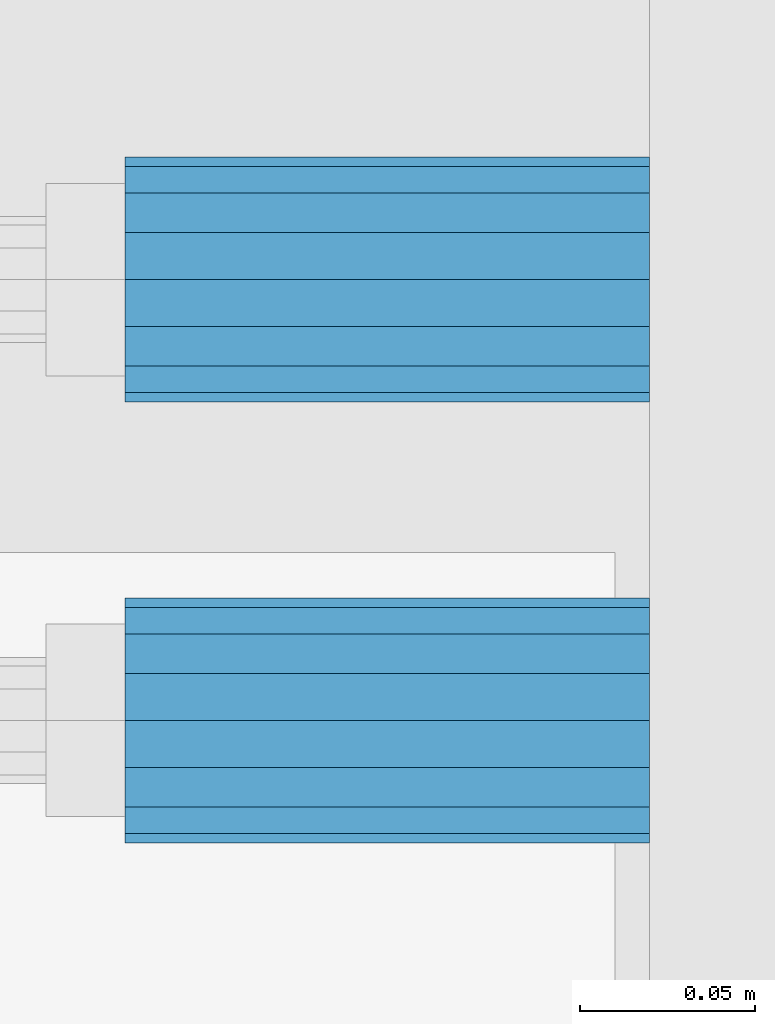
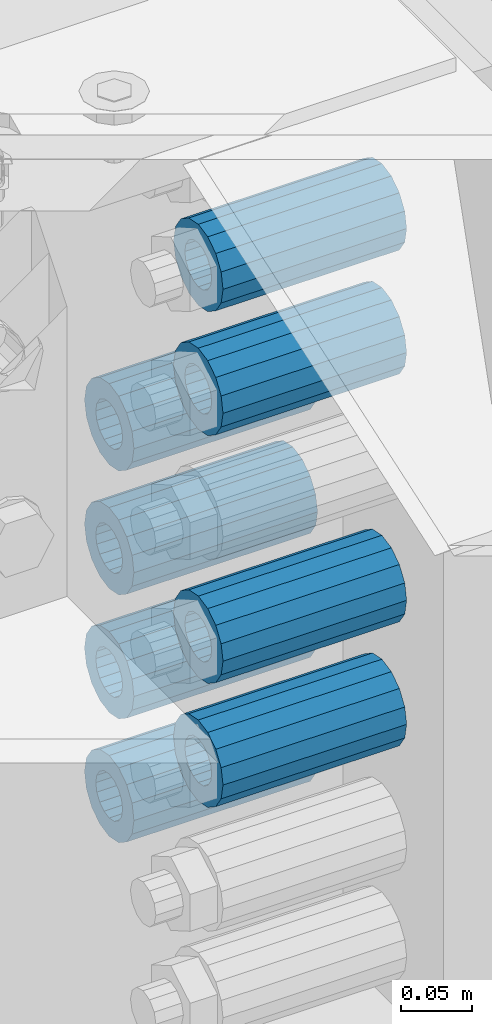
# One storey, part 143 of 208: 8 beams.
"""IFC2X3 building model written with IfcOpenShell, lengths in millimetres."""

from ifc_helpers import new_model, si_unit, frame, origin_with_axes, place, context, subcontext, project, spatial, faceted_brep, material, type_object, element, save


model = new_model("IFC2X3")

# Units and contexts
model_context = context("Model", 3, precision=1e-05, world=origin_with_axes())
body_context = subcontext(model_context, "Body", "Model", "MODEL_VIEW")
ifc_project = project(units=[si_unit("LENGTHUNIT", "METRE", prefix="MILLI"), si_unit("AREAUNIT", "SQUARE_METRE"), si_unit("VOLUMEUNIT", "CUBIC_METRE"), si_unit("MASSUNIT", "GRAM", prefix="KILO"), si_unit("TIMEUNIT", "SECOND"), si_unit("PLANEANGLEUNIT", "RADIAN"), si_unit("SOLIDANGLEUNIT", "STERADIAN"), si_unit("THERMODYNAMICTEMPERATUREUNIT", "DEGREE_CELSIUS"), si_unit("LUMINOUSINTENSITYUNIT", "LUMEN")], contexts=[model_context])

# Site, building, storey
site_placement = place(None, origin_with_axes())
site = spatial("IfcSite", under=ifc_project, at=site_placement, CompositionType="ELEMENT")
building_placement = place(site_placement, origin_with_axes())
building = spatial("IfcBuilding", under=site, at=building_placement, Name="Standard", CompositionType="ELEMENT")
storey_placement = place(building_placement, origin_with_axes())
storey = spatial("IfcBuildingStorey", under=building, at=storey_placement, Name="Undefined", CompositionType="ELEMENT", Elevation=0.0)

# Beams
ifc_material = material()
beam_type = type_object("IfcBeamType", PredefinedType="NOTDEFINED")
beam_1_placement = place(storey_placement, frame((-25783.0, 6063.0, -499.0), z_axis=(0.0, 0.0, 1.0), x_axis=(1.0, 0.0, 0.0)))
element("IfcBeam", 1, at=beam_1_placement, inside=storey, type_object=beam_type, material=ifc_material, context=body_context, shape_type="Brep", body=[
    faceted_brep([(-1.3120632047503e-07, -18.9999999995496, -6.26459950581193e-09), (0.0, -17.5537111177146, 7.27098521493672), (150.0, -17.5537111177146, 7.27098521493672), (150.0, -19.0, 0.0), (0.0, -13.4350288425444, 13.4350288425444), (150.0, -13.4350288425444, 13.4350288425444), (0.0, -7.2709852149369, 17.5537111177144), (150.0, -7.2709852149369, 17.5537111177144), (-6.33906438451959e-09, 4.50199877377599e-10, 18.9999999937354), (150.0, 0.0, 19.0), (0.0, 7.2709852149369, 17.5537111177144), (150.0, 7.2709852149369, 17.5537111177144), (0.0, 13.4350288425444, 13.4350288425444), (150.0, 13.4350288425444, 13.4350288425444), (0.0, 17.5537111177146, 7.2709852149367), (150.0, 17.5537111177146, 7.2709852149367), (1.33208345687308e-07, 19.0000000004507, -6.26459950581193e-09), (150.0, 19.0, 0.0), (0.0, 17.5537111177146, -7.2709852149367), (150.0, 17.5537111177146, -7.2709852149367), (0.0, 13.4350288425444, -13.4350288425444), (150.0, 13.4350288425444, -13.4350288425444), (0.0, 7.2709852149369, -17.5537111177144), (150.0, 7.2709852149369, -17.5537111177144), (8.34120328363497e-09, 4.50427251053043e-10, -19.0000000062646), (150.0, 0.0, -19.0), (0.0, -7.2709852149369, -17.5537111177144), (150.0, -7.2709852149369, -17.5537111177144), (0.0, -13.4350288425444, -13.4350288425444), (150.0, -13.4350288425444, -13.4350288425444), (0.0, -17.5537111177146, -7.2709852149367), (150.0, -17.5537111177146, -7.2709852149367), (0.0, -35.0, 0.0), (-3.63797880709171e-12, -32.335783637895, -13.3939201327782), (150.0, -32.335783637895, -13.3939201327782), (150.0, -35.0, 0.0), (0.0, -24.7487373415292, -24.7487373415291), (150.0, -24.7487373415293, -24.7487373415292), (0.0, -13.3939201327781, -32.335783637895), (150.0, -13.393920132778, -32.335783637895), (0.0, 0.0, -35.0), (150.0, 0.0, -35.0), (0.0, 13.3939201327782, -32.335783637895), (150.0, 13.393920132778, -32.335783637895), (0.0, 24.7487373415292, -24.7487373415291), (150.0, 24.7487373415293, -24.7487373415292), (-3.63797880709171e-12, 32.335783637895, -13.3939201327782), (150.0, 32.335783637895, -13.3939201327781), (0.0, 35.0, 0.0), (150.0, 35.0, 0.0), (0.0, 32.335783637895, 13.3939201327781), (150.0, 32.335783637895, 13.3939201327781), (0.0, 24.7487373415292, 24.748737341529), (150.0, 24.7487373415293, 24.7487373415292), (0.0, 13.3939201327781, 32.335783637895), (150.0, 13.393920132778, 32.335783637895), (-3.63797880709171e-12, 0.0, 35.0), (150.0, 0.0, 35.0), (0.0, -13.3939201327781, 32.335783637895), (150.0, -13.393920132778, 32.335783637895), (0.0, -24.7487373415292, 24.748737341529), (150.0, -24.7487373415293, 24.7487373415292), (0.0, -32.335783637895, 13.3939201327781), (150.0, -32.335783637895, 13.3939201327781)], [[[0, 1, 2, 3]], [[1, 4, 5, 2]], [[4, 6, 7, 5]], [[6, 8, 9, 7]], [[8, 10, 11, 9]], [[10, 12, 13, 11]], [[12, 14, 15, 13]], [[14, 16, 17, 15]], [[16, 18, 19, 17]], [[18, 20, 21, 19]], [[20, 22, 23, 21]], [[22, 24, 25, 23]], [[24, 26, 27, 25]], [[26, 28, 29, 27]], [[28, 30, 31, 29]], [[30, 0, 3, 31]], [[32, 33, 34, 35]], [[33, 36, 37, 34]], [[36, 38, 39, 37]], [[38, 40, 41, 39]], [[40, 42, 43, 41]], [[42, 44, 45, 43]], [[44, 46, 47, 45]], [[46, 48, 49, 47]], [[48, 50, 51, 49]], [[50, 52, 53, 51]], [[52, 54, 55, 53]], [[54, 56, 57, 55]], [[56, 58, 59, 57]], [[58, 60, 61, 59]], [[60, 62, 63, 61]], [[62, 32, 35, 63]], [[37, 39, 41, 43, 45, 47, 49, 51, 53, 55, 57, 59, 61, 63, 35, 34], [5, 7, 9, 11, 13, 15, 17, 19, 21, 23, 25, 27, 29, 31, 3, 2]], [[62, 60, 58, 56, 54, 52, 50, 48, 46, 44, 42, 40, 38, 36, 33, 32], [30, 28, 26, 24, 22, 20, 18, 16, 14, 12, 10, 8, 6, 4, 1, 0]]]),
])
beam_2_placement = place(storey_placement, frame((-25783.0, 5937.0, -285.0), z_axis=(0.0, 0.0, 1.0), x_axis=(1.0, 0.0, 0.0)))
element("IfcBeam", 2, at=beam_2_placement, inside=storey, type_object=beam_type, material=ifc_material, context=body_context, shape_type="Brep", body=[
    faceted_brep([(-1.3120632047503e-07, -18.9999999995496, -6.26459950581193e-09), (0.0, -17.5537111177146, 7.27098521493672), (150.0, -17.5537111177146, 7.27098521493672), (150.0, -19.0, 0.0), (0.0, -13.4350288425444, 13.4350288425444), (150.0, -13.4350288425444, 13.4350288425444), (0.0, -7.2709852149369, 17.5537111177144), (150.0, -7.2709852149369, 17.5537111177144), (-6.33906438451959e-09, 4.50199877377599e-10, 18.9999999937354), (150.0, 0.0, 19.0), (0.0, 7.2709852149369, 17.5537111177144), (150.0, 7.2709852149369, 17.5537111177144), (0.0, 13.4350288425444, 13.4350288425444), (150.0, 13.4350288425444, 13.4350288425444), (0.0, 17.5537111177146, 7.2709852149367), (150.0, 17.5537111177146, 7.2709852149367), (1.33208345687308e-07, 19.0000000004507, -6.26459950581193e-09), (150.0, 19.0, 0.0), (0.0, 17.5537111177146, -7.2709852149367), (150.0, 17.5537111177146, -7.2709852149367), (0.0, 13.4350288425444, -13.4350288425444), (150.0, 13.4350288425444, -13.4350288425444), (0.0, 7.2709852149369, -17.5537111177144), (150.0, 7.2709852149369, -17.5537111177144), (8.34120328363497e-09, 4.50427251053043e-10, -19.0000000062646), (150.0, 0.0, -19.0), (0.0, -7.2709852149369, -17.5537111177144), (150.0, -7.2709852149369, -17.5537111177144), (0.0, -13.4350288425444, -13.4350288425444), (150.0, -13.4350288425444, -13.4350288425444), (0.0, -17.5537111177146, -7.2709852149367), (150.0, -17.5537111177146, -7.2709852149367), (0.0, -35.0, 0.0), (-3.63797880709171e-12, -32.335783637895, -13.3939201327782), (150.0, -32.335783637895, -13.3939201327782), (150.0, -35.0, 0.0), (0.0, -24.7487373415292, -24.7487373415291), (150.0, -24.7487373415293, -24.7487373415292), (0.0, -13.3939201327781, -32.335783637895), (150.0, -13.393920132778, -32.335783637895), (0.0, 0.0, -35.0), (150.0, 0.0, -35.0), (0.0, 13.3939201327782, -32.335783637895), (150.0, 13.393920132778, -32.335783637895), (0.0, 24.7487373415292, -24.7487373415291), (150.0, 24.7487373415293, -24.7487373415292), (-3.63797880709171e-12, 32.335783637895, -13.3939201327782), (150.0, 32.335783637895, -13.3939201327781), (0.0, 35.0, 0.0), (150.0, 35.0, 0.0), (0.0, 32.335783637895, 13.3939201327781), (150.0, 32.335783637895, 13.3939201327781), (0.0, 24.7487373415292, 24.748737341529), (150.0, 24.7487373415293, 24.7487373415292), (0.0, 13.3939201327781, 32.335783637895), (150.0, 13.393920132778, 32.335783637895), (-3.63797880709171e-12, 0.0, 35.0), (150.0, 0.0, 35.0), (0.0, -13.3939201327781, 32.335783637895), (150.0, -13.393920132778, 32.335783637895), (0.0, -24.7487373415292, 24.748737341529), (150.0, -24.7487373415293, 24.7487373415292), (0.0, -32.335783637895, 13.3939201327781), (150.0, -32.335783637895, 13.3939201327781)], [[[0, 1, 2, 3]], [[1, 4, 5, 2]], [[4, 6, 7, 5]], [[6, 8, 9, 7]], [[8, 10, 11, 9]], [[10, 12, 13, 11]], [[12, 14, 15, 13]], [[14, 16, 17, 15]], [[16, 18, 19, 17]], [[18, 20, 21, 19]], [[20, 22, 23, 21]], [[22, 24, 25, 23]], [[24, 26, 27, 25]], [[26, 28, 29, 27]], [[28, 30, 31, 29]], [[30, 0, 3, 31]], [[32, 33, 34, 35]], [[33, 36, 37, 34]], [[36, 38, 39, 37]], [[38, 40, 41, 39]], [[40, 42, 43, 41]], [[42, 44, 45, 43]], [[44, 46, 47, 45]], [[46, 48, 49, 47]], [[48, 50, 51, 49]], [[50, 52, 53, 51]], [[52, 54, 55, 53]], [[54, 56, 57, 55]], [[56, 58, 59, 57]], [[58, 60, 61, 59]], [[60, 62, 63, 61]], [[62, 32, 35, 63]], [[37, 39, 41, 43, 45, 47, 49, 51, 53, 55, 57, 59, 61, 63, 35, 34], [5, 7, 9, 11, 13, 15, 17, 19, 21, 23, 25, 27, 29, 31, 3, 2]], [[62, 60, 58, 56, 54, 52, 50, 48, 46, 44, 42, 40, 38, 36, 33, 32], [30, 28, 26, 24, 22, 20, 18, 16, 14, 12, 10, 8, 6, 4, 1, 0]]]),
])
beam_3_placement = place(storey_placement, frame((-25783.0, 5937.0, -499.0), z_axis=(0.0, 0.0, 1.0), x_axis=(1.0, 0.0, 0.0)))
element("IfcBeam", 3, at=beam_3_placement, inside=storey, type_object=beam_type, material=ifc_material, context=body_context, shape_type="Brep", body=[
    faceted_brep([(-1.3120632047503e-07, -18.9999999995496, -6.26459950581193e-09), (0.0, -17.5537111177146, 7.27098521493672), (150.0, -17.5537111177146, 7.27098521493672), (150.0, -19.0, 0.0), (0.0, -13.4350288425444, 13.4350288425444), (150.0, -13.4350288425444, 13.4350288425444), (0.0, -7.2709852149369, 17.5537111177144), (150.0, -7.2709852149369, 17.5537111177144), (-6.33906438451959e-09, 4.50199877377599e-10, 18.9999999937354), (150.0, 0.0, 19.0), (0.0, 7.2709852149369, 17.5537111177144), (150.0, 7.2709852149369, 17.5537111177144), (0.0, 13.4350288425444, 13.4350288425444), (150.0, 13.4350288425444, 13.4350288425444), (0.0, 17.5537111177146, 7.2709852149367), (150.0, 17.5537111177146, 7.2709852149367), (1.33208345687308e-07, 19.0000000004507, -6.26459950581193e-09), (150.0, 19.0, 0.0), (0.0, 17.5537111177146, -7.2709852149367), (150.0, 17.5537111177146, -7.2709852149367), (0.0, 13.4350288425444, -13.4350288425444), (150.0, 13.4350288425444, -13.4350288425444), (0.0, 7.2709852149369, -17.5537111177144), (150.0, 7.2709852149369, -17.5537111177144), (8.34120328363497e-09, 4.50427251053043e-10, -19.0000000062646), (150.0, 0.0, -19.0), (0.0, -7.2709852149369, -17.5537111177144), (150.0, -7.2709852149369, -17.5537111177144), (0.0, -13.4350288425444, -13.4350288425444), (150.0, -13.4350288425444, -13.4350288425444), (0.0, -17.5537111177146, -7.2709852149367), (150.0, -17.5537111177146, -7.2709852149367), (0.0, -35.0, 0.0), (-3.63797880709171e-12, -32.335783637895, -13.3939201327782), (150.0, -32.335783637895, -13.3939201327782), (150.0, -35.0, 0.0), (0.0, -24.7487373415292, -24.7487373415291), (150.0, -24.7487373415293, -24.7487373415292), (0.0, -13.3939201327781, -32.335783637895), (150.0, -13.393920132778, -32.335783637895), (0.0, 0.0, -35.0), (150.0, 0.0, -35.0), (0.0, 13.3939201327782, -32.335783637895), (150.0, 13.393920132778, -32.335783637895), (0.0, 24.7487373415292, -24.7487373415291), (150.0, 24.7487373415293, -24.7487373415292), (-3.63797880709171e-12, 32.335783637895, -13.3939201327782), (150.0, 32.335783637895, -13.3939201327781), (0.0, 35.0, 0.0), (150.0, 35.0, 0.0), (0.0, 32.335783637895, 13.3939201327781), (150.0, 32.335783637895, 13.3939201327781), (0.0, 24.7487373415292, 24.748737341529), (150.0, 24.7487373415293, 24.7487373415292), (0.0, 13.3939201327781, 32.335783637895), (150.0, 13.393920132778, 32.335783637895), (-3.63797880709171e-12, 0.0, 35.0), (150.0, 0.0, 35.0), (0.0, -13.3939201327781, 32.335783637895), (150.0, -13.393920132778, 32.335783637895), (0.0, -24.7487373415292, 24.748737341529), (150.0, -24.7487373415293, 24.7487373415292), (0.0, -32.335783637895, 13.3939201327781), (150.0, -32.335783637895, 13.3939201327781)], [[[0, 1, 2, 3]], [[1, 4, 5, 2]], [[4, 6, 7, 5]], [[6, 8, 9, 7]], [[8, 10, 11, 9]], [[10, 12, 13, 11]], [[12, 14, 15, 13]], [[14, 16, 17, 15]], [[16, 18, 19, 17]], [[18, 20, 21, 19]], [[20, 22, 23, 21]], [[22, 24, 25, 23]], [[24, 26, 27, 25]], [[26, 28, 29, 27]], [[28, 30, 31, 29]], [[30, 0, 3, 31]], [[32, 33, 34, 35]], [[33, 36, 37, 34]], [[36, 38, 39, 37]], [[38, 40, 41, 39]], [[40, 42, 43, 41]], [[42, 44, 45, 43]], [[44, 46, 47, 45]], [[46, 48, 49, 47]], [[48, 50, 51, 49]], [[50, 52, 53, 51]], [[52, 54, 55, 53]], [[54, 56, 57, 55]], [[56, 58, 59, 57]], [[58, 60, 61, 59]], [[60, 62, 63, 61]], [[62, 32, 35, 63]], [[37, 39, 41, 43, 45, 47, 49, 51, 53, 55, 57, 59, 61, 63, 35, 34], [5, 7, 9, 11, 13, 15, 17, 19, 21, 23, 25, 27, 29, 31, 3, 2]], [[62, 60, 58, 56, 54, 52, 50, 48, 46, 44, 42, 40, 38, 36, 33, 32], [30, 28, 26, 24, 22, 20, 18, 16, 14, 12, 10, 8, 6, 4, 1, 0]]]),
])
beam_4_placement = place(storey_placement, frame((-25783.0, 6063.0, -392.0), z_axis=(0.0, 0.0, 1.0), x_axis=(1.0, 0.0, 0.0)))
element("IfcBeam", 4, at=beam_4_placement, inside=storey, type_object=beam_type, material=ifc_material, context=body_context, shape_type="Brep", body=[
    faceted_brep([(-1.3120632047503e-07, -18.9999999995496, -6.26459950581193e-09), (0.0, -17.5537111177146, 7.27098521493672), (150.0, -17.5537111177146, 7.27098521493672), (150.0, -19.0, 0.0), (0.0, -13.4350288425444, 13.4350288425444), (150.0, -13.4350288425444, 13.4350288425444), (0.0, -7.2709852149369, 17.5537111177144), (150.0, -7.2709852149369, 17.5537111177144), (-6.33906438451959e-09, 4.50199877377599e-10, 18.9999999937354), (150.0, 0.0, 19.0), (0.0, 7.2709852149369, 17.5537111177144), (150.0, 7.2709852149369, 17.5537111177144), (0.0, 13.4350288425444, 13.4350288425444), (150.0, 13.4350288425444, 13.4350288425444), (0.0, 17.5537111177146, 7.2709852149367), (150.0, 17.5537111177146, 7.2709852149367), (1.33208345687308e-07, 19.0000000004507, -6.26459950581193e-09), (150.0, 19.0, 0.0), (0.0, 17.5537111177146, -7.2709852149367), (150.0, 17.5537111177146, -7.2709852149367), (0.0, 13.4350288425444, -13.4350288425444), (150.0, 13.4350288425444, -13.4350288425444), (0.0, 7.2709852149369, -17.5537111177144), (150.0, 7.2709852149369, -17.5537111177144), (8.34120328363497e-09, 4.50427251053043e-10, -19.0000000062646), (150.0, 0.0, -19.0), (0.0, -7.2709852149369, -17.5537111177144), (150.0, -7.2709852149369, -17.5537111177144), (0.0, -13.4350288425444, -13.4350288425444), (150.0, -13.4350288425444, -13.4350288425444), (0.0, -17.5537111177146, -7.2709852149367), (150.0, -17.5537111177146, -7.2709852149367), (0.0, -35.0, 0.0), (-3.63797880709171e-12, -32.335783637895, -13.3939201327782), (150.0, -32.335783637895, -13.3939201327782), (150.0, -35.0, 0.0), (0.0, -24.7487373415292, -24.7487373415291), (150.0, -24.7487373415293, -24.7487373415292), (0.0, -13.3939201327781, -32.335783637895), (150.0, -13.393920132778, -32.335783637895), (0.0, 0.0, -35.0), (150.0, 0.0, -35.0), (0.0, 13.3939201327782, -32.335783637895), (150.0, 13.393920132778, -32.335783637895), (0.0, 24.7487373415292, -24.7487373415291), (150.0, 24.7487373415293, -24.7487373415292), (-3.63797880709171e-12, 32.335783637895, -13.3939201327782), (150.0, 32.335783637895, -13.3939201327781), (0.0, 35.0, 0.0), (150.0, 35.0, 0.0), (0.0, 32.335783637895, 13.3939201327781), (150.0, 32.335783637895, 13.3939201327781), (0.0, 24.7487373415292, 24.748737341529), (150.0, 24.7487373415293, 24.7487373415292), (0.0, 13.3939201327781, 32.335783637895), (150.0, 13.393920132778, 32.335783637895), (-3.63797880709171e-12, 0.0, 35.0), (150.0, 0.0, 35.0), (0.0, -13.3939201327781, 32.335783637895), (150.0, -13.393920132778, 32.335783637895), (0.0, -24.7487373415292, 24.748737341529), (150.0, -24.7487373415293, 24.7487373415292), (0.0, -32.335783637895, 13.3939201327781), (150.0, -32.335783637895, 13.3939201327781)], [[[0, 1, 2, 3]], [[1, 4, 5, 2]], [[4, 6, 7, 5]], [[6, 8, 9, 7]], [[8, 10, 11, 9]], [[10, 12, 13, 11]], [[12, 14, 15, 13]], [[14, 16, 17, 15]], [[16, 18, 19, 17]], [[18, 20, 21, 19]], [[20, 22, 23, 21]], [[22, 24, 25, 23]], [[24, 26, 27, 25]], [[26, 28, 29, 27]], [[28, 30, 31, 29]], [[30, 0, 3, 31]], [[32, 33, 34, 35]], [[33, 36, 37, 34]], [[36, 38, 39, 37]], [[38, 40, 41, 39]], [[40, 42, 43, 41]], [[42, 44, 45, 43]], [[44, 46, 47, 45]], [[46, 48, 49, 47]], [[48, 50, 51, 49]], [[50, 52, 53, 51]], [[52, 54, 55, 53]], [[54, 56, 57, 55]], [[56, 58, 59, 57]], [[58, 60, 61, 59]], [[60, 62, 63, 61]], [[62, 32, 35, 63]], [[37, 39, 41, 43, 45, 47, 49, 51, 53, 55, 57, 59, 61, 63, 35, 34], [5, 7, 9, 11, 13, 15, 17, 19, 21, 23, 25, 27, 29, 31, 3, 2]], [[62, 60, 58, 56, 54, 52, 50, 48, 46, 44, 42, 40, 38, 36, 33, 32], [30, 28, 26, 24, 22, 20, 18, 16, 14, 12, 10, 8, 6, 4, 1, 0]]]),
])
beam_5_placement = place(storey_placement, frame((-25783.0, 6063.0, -606.0), z_axis=(0.0, 0.0, 1.0), x_axis=(1.0, 0.0, 0.0)))
element("IfcBeam", 5, at=beam_5_placement, inside=storey, type_object=beam_type, material=ifc_material, context=body_context, shape_type="Brep", body=[
    faceted_brep([(-1.3120632047503e-07, -18.9999999995496, -6.26459950581193e-09), (0.0, -17.5537111177146, 7.27098521493672), (150.0, -17.5537111177146, 7.27098521493672), (150.0, -19.0, 0.0), (0.0, -13.4350288425444, 13.4350288425444), (150.0, -13.4350288425444, 13.4350288425444), (0.0, -7.2709852149369, 17.5537111177144), (150.0, -7.2709852149369, 17.5537111177144), (-6.33906438451959e-09, 4.50199877377599e-10, 18.9999999937354), (150.0, 0.0, 19.0), (0.0, 7.2709852149369, 17.5537111177144), (150.0, 7.2709852149369, 17.5537111177144), (0.0, 13.4350288425444, 13.4350288425444), (150.0, 13.4350288425444, 13.4350288425444), (0.0, 17.5537111177146, 7.2709852149367), (150.0, 17.5537111177146, 7.2709852149367), (1.33208345687308e-07, 19.0000000004507, -6.26459950581193e-09), (150.0, 19.0, 0.0), (0.0, 17.5537111177146, -7.2709852149367), (150.0, 17.5537111177146, -7.2709852149367), (0.0, 13.4350288425444, -13.4350288425444), (150.0, 13.4350288425444, -13.4350288425444), (0.0, 7.2709852149369, -17.5537111177144), (150.0, 7.2709852149369, -17.5537111177144), (8.34120328363497e-09, 4.50427251053043e-10, -19.0000000062646), (150.0, 0.0, -19.0), (0.0, -7.2709852149369, -17.5537111177144), (150.0, -7.2709852149369, -17.5537111177144), (0.0, -13.4350288425444, -13.4350288425444), (150.0, -13.4350288425444, -13.4350288425444), (0.0, -17.5537111177146, -7.2709852149367), (150.0, -17.5537111177146, -7.2709852149367), (0.0, -35.0, 0.0), (-3.63797880709171e-12, -32.335783637895, -13.3939201327782), (150.0, -32.335783637895, -13.3939201327782), (150.0, -35.0, 0.0), (0.0, -24.7487373415292, -24.7487373415291), (150.0, -24.7487373415293, -24.7487373415292), (0.0, -13.3939201327781, -32.335783637895), (150.0, -13.393920132778, -32.335783637895), (0.0, 0.0, -35.0), (150.0, 0.0, -35.0), (0.0, 13.3939201327782, -32.335783637895), (150.0, 13.393920132778, -32.335783637895), (0.0, 24.7487373415292, -24.7487373415291), (150.0, 24.7487373415293, -24.7487373415292), (-3.63797880709171e-12, 32.335783637895, -13.3939201327782), (150.0, 32.335783637895, -13.3939201327781), (0.0, 35.0, 0.0), (150.0, 35.0, 0.0), (0.0, 32.335783637895, 13.3939201327781), (150.0, 32.335783637895, 13.3939201327781), (0.0, 24.7487373415292, 24.748737341529), (150.0, 24.7487373415293, 24.7487373415292), (0.0, 13.3939201327781, 32.335783637895), (150.0, 13.393920132778, 32.335783637895), (-3.63797880709171e-12, 0.0, 35.0), (150.0, 0.0, 35.0), (0.0, -13.3939201327781, 32.335783637895), (150.0, -13.393920132778, 32.335783637895), (0.0, -24.7487373415292, 24.748737341529), (150.0, -24.7487373415293, 24.7487373415292), (0.0, -32.335783637895, 13.3939201327781), (150.0, -32.335783637895, 13.3939201327781)], [[[0, 1, 2, 3]], [[1, 4, 5, 2]], [[4, 6, 7, 5]], [[6, 8, 9, 7]], [[8, 10, 11, 9]], [[10, 12, 13, 11]], [[12, 14, 15, 13]], [[14, 16, 17, 15]], [[16, 18, 19, 17]], [[18, 20, 21, 19]], [[20, 22, 23, 21]], [[22, 24, 25, 23]], [[24, 26, 27, 25]], [[26, 28, 29, 27]], [[28, 30, 31, 29]], [[30, 0, 3, 31]], [[32, 33, 34, 35]], [[33, 36, 37, 34]], [[36, 38, 39, 37]], [[38, 40, 41, 39]], [[40, 42, 43, 41]], [[42, 44, 45, 43]], [[44, 46, 47, 45]], [[46, 48, 49, 47]], [[48, 50, 51, 49]], [[50, 52, 53, 51]], [[52, 54, 55, 53]], [[54, 56, 57, 55]], [[56, 58, 59, 57]], [[58, 60, 61, 59]], [[60, 62, 63, 61]], [[62, 32, 35, 63]], [[37, 39, 41, 43, 45, 47, 49, 51, 53, 55, 57, 59, 61, 63, 35, 34], [5, 7, 9, 11, 13, 15, 17, 19, 21, 23, 25, 27, 29, 31, 3, 2]], [[62, 60, 58, 56, 54, 52, 50, 48, 46, 44, 42, 40, 38, 36, 33, 32], [30, 28, 26, 24, 22, 20, 18, 16, 14, 12, 10, 8, 6, 4, 1, 0]]]),
])
beam_6_placement = place(storey_placement, frame((-25783.0, 5937.0, -606.0), z_axis=(0.0, 0.0, 1.0), x_axis=(1.0, 0.0, 0.0)))
element("IfcBeam", 6, at=beam_6_placement, inside=storey, type_object=beam_type, material=ifc_material, context=body_context, shape_type="Brep", body=[
    faceted_brep([(-1.3120632047503e-07, -18.9999999995496, -6.26459950581193e-09), (0.0, -17.5537111177146, 7.27098521493672), (150.0, -17.5537111177146, 7.27098521493672), (150.0, -19.0, 0.0), (0.0, -13.4350288425444, 13.4350288425444), (150.0, -13.4350288425444, 13.4350288425444), (0.0, -7.2709852149369, 17.5537111177144), (150.0, -7.2709852149369, 17.5537111177144), (-6.33906438451959e-09, 4.50199877377599e-10, 18.9999999937354), (150.0, 0.0, 19.0), (0.0, 7.2709852149369, 17.5537111177144), (150.0, 7.2709852149369, 17.5537111177144), (0.0, 13.4350288425444, 13.4350288425444), (150.0, 13.4350288425444, 13.4350288425444), (0.0, 17.5537111177146, 7.2709852149367), (150.0, 17.5537111177146, 7.2709852149367), (1.33208345687308e-07, 19.0000000004507, -6.26459950581193e-09), (150.0, 19.0, 0.0), (0.0, 17.5537111177146, -7.2709852149367), (150.0, 17.5537111177146, -7.2709852149367), (0.0, 13.4350288425444, -13.4350288425444), (150.0, 13.4350288425444, -13.4350288425444), (0.0, 7.2709852149369, -17.5537111177144), (150.0, 7.2709852149369, -17.5537111177144), (8.34120328363497e-09, 4.50427251053043e-10, -19.0000000062646), (150.0, 0.0, -19.0), (0.0, -7.2709852149369, -17.5537111177144), (150.0, -7.2709852149369, -17.5537111177144), (0.0, -13.4350288425444, -13.4350288425444), (150.0, -13.4350288425444, -13.4350288425444), (0.0, -17.5537111177146, -7.2709852149367), (150.0, -17.5537111177146, -7.2709852149367), (0.0, -35.0, 0.0), (-3.63797880709171e-12, -32.335783637895, -13.3939201327782), (150.0, -32.335783637895, -13.3939201327782), (150.0, -35.0, 0.0), (0.0, -24.7487373415292, -24.7487373415291), (150.0, -24.7487373415293, -24.7487373415292), (0.0, -13.3939201327781, -32.335783637895), (150.0, -13.393920132778, -32.335783637895), (0.0, 0.0, -35.0), (150.0, 0.0, -35.0), (0.0, 13.3939201327782, -32.335783637895), (150.0, 13.393920132778, -32.335783637895), (0.0, 24.7487373415292, -24.7487373415291), (150.0, 24.7487373415293, -24.7487373415292), (-3.63797880709171e-12, 32.335783637895, -13.3939201327782), (150.0, 32.335783637895, -13.3939201327781), (0.0, 35.0, 0.0), (150.0, 35.0, 0.0), (0.0, 32.335783637895, 13.3939201327781), (150.0, 32.335783637895, 13.3939201327781), (0.0, 24.7487373415292, 24.748737341529), (150.0, 24.7487373415293, 24.7487373415292), (0.0, 13.3939201327781, 32.335783637895), (150.0, 13.393920132778, 32.335783637895), (-3.63797880709171e-12, 0.0, 35.0), (150.0, 0.0, 35.0), (0.0, -13.3939201327781, 32.335783637895), (150.0, -13.393920132778, 32.335783637895), (0.0, -24.7487373415292, 24.748737341529), (150.0, -24.7487373415293, 24.7487373415292), (0.0, -32.335783637895, 13.3939201327781), (150.0, -32.335783637895, 13.3939201327781)], [[[0, 1, 2, 3]], [[1, 4, 5, 2]], [[4, 6, 7, 5]], [[6, 8, 9, 7]], [[8, 10, 11, 9]], [[10, 12, 13, 11]], [[12, 14, 15, 13]], [[14, 16, 17, 15]], [[16, 18, 19, 17]], [[18, 20, 21, 19]], [[20, 22, 23, 21]], [[22, 24, 25, 23]], [[24, 26, 27, 25]], [[26, 28, 29, 27]], [[28, 30, 31, 29]], [[30, 0, 3, 31]], [[32, 33, 34, 35]], [[33, 36, 37, 34]], [[36, 38, 39, 37]], [[38, 40, 41, 39]], [[40, 42, 43, 41]], [[42, 44, 45, 43]], [[44, 46, 47, 45]], [[46, 48, 49, 47]], [[48, 50, 51, 49]], [[50, 52, 53, 51]], [[52, 54, 55, 53]], [[54, 56, 57, 55]], [[56, 58, 59, 57]], [[58, 60, 61, 59]], [[60, 62, 63, 61]], [[62, 32, 35, 63]], [[37, 39, 41, 43, 45, 47, 49, 51, 53, 55, 57, 59, 61, 63, 35, 34], [5, 7, 9, 11, 13, 15, 17, 19, 21, 23, 25, 27, 29, 31, 3, 2]], [[62, 60, 58, 56, 54, 52, 50, 48, 46, 44, 42, 40, 38, 36, 33, 32], [30, 28, 26, 24, 22, 20, 18, 16, 14, 12, 10, 8, 6, 4, 1, 0]]]),
])
beam_7_placement = place(storey_placement, frame((-25783.0, 5937.0, -178.0), z_axis=(0.0, 0.0, 1.0), x_axis=(1.0, 0.0, 0.0)))
element("IfcBeam", 7, at=beam_7_placement, inside=storey, type_object=beam_type, material=ifc_material, context=body_context, shape_type="Brep", body=[
    faceted_brep([(-1.3120632047503e-07, -18.9999999995496, -6.26459950581193e-09), (0.0, -17.5537111177146, 7.27098521493672), (150.0, -17.5537111177146, 7.27098521493672), (150.0, -19.0, 0.0), (0.0, -13.4350288425444, 13.4350288425444), (150.0, -13.4350288425444, 13.4350288425444), (0.0, -7.2709852149369, 17.5537111177144), (150.0, -7.2709852149369, 17.5537111177144), (-6.33906438451959e-09, 4.50199877377599e-10, 18.9999999937354), (150.0, 0.0, 19.0), (0.0, 7.2709852149369, 17.5537111177144), (150.0, 7.2709852149369, 17.5537111177144), (0.0, 13.4350288425444, 13.4350288425444), (150.0, 13.4350288425444, 13.4350288425444), (0.0, 17.5537111177146, 7.2709852149367), (150.0, 17.5537111177146, 7.2709852149367), (1.33208345687308e-07, 19.0000000004507, -6.26459950581193e-09), (150.0, 19.0, 0.0), (0.0, 17.5537111177146, -7.2709852149367), (150.0, 17.5537111177146, -7.2709852149367), (0.0, 13.4350288425444, -13.4350288425444), (150.0, 13.4350288425444, -13.4350288425444), (0.0, 7.2709852149369, -17.5537111177144), (150.0, 7.2709852149369, -17.5537111177144), (8.34120328363497e-09, 4.50427251053043e-10, -19.0000000062646), (150.0, 0.0, -19.0), (0.0, -7.2709852149369, -17.5537111177144), (150.0, -7.2709852149369, -17.5537111177144), (0.0, -13.4350288425444, -13.4350288425444), (150.0, -13.4350288425444, -13.4350288425444), (0.0, -17.5537111177146, -7.2709852149367), (150.0, -17.5537111177146, -7.2709852149367), (0.0, -35.0, 0.0), (-3.63797880709171e-12, -32.335783637895, -13.3939201327782), (150.0, -32.335783637895, -13.3939201327782), (150.0, -35.0, 0.0), (0.0, -24.7487373415292, -24.7487373415291), (150.0, -24.7487373415293, -24.7487373415292), (0.0, -13.3939201327781, -32.335783637895), (150.0, -13.393920132778, -32.335783637895), (0.0, 0.0, -35.0), (150.0, 0.0, -35.0), (0.0, 13.3939201327782, -32.335783637895), (150.0, 13.393920132778, -32.335783637895), (0.0, 24.7487373415292, -24.7487373415291), (150.0, 24.7487373415293, -24.7487373415292), (-3.63797880709171e-12, 32.335783637895, -13.3939201327782), (150.0, 32.335783637895, -13.3939201327781), (0.0, 35.0, 0.0), (150.0, 35.0, 0.0), (0.0, 32.335783637895, 13.3939201327781), (150.0, 32.335783637895, 13.3939201327781), (0.0, 24.7487373415292, 24.748737341529), (150.0, 24.7487373415293, 24.7487373415292), (0.0, 13.3939201327781, 32.335783637895), (150.0, 13.393920132778, 32.335783637895), (-3.63797880709171e-12, 0.0, 35.0), (150.0, 0.0, 35.0), (0.0, -13.3939201327781, 32.335783637895), (150.0, -13.393920132778, 32.335783637895), (0.0, -24.7487373415292, 24.748737341529), (150.0, -24.7487373415293, 24.7487373415292), (0.0, -32.335783637895, 13.3939201327781), (150.0, -32.335783637895, 13.3939201327781)], [[[0, 1, 2, 3]], [[1, 4, 5, 2]], [[4, 6, 7, 5]], [[6, 8, 9, 7]], [[8, 10, 11, 9]], [[10, 12, 13, 11]], [[12, 14, 15, 13]], [[14, 16, 17, 15]], [[16, 18, 19, 17]], [[18, 20, 21, 19]], [[20, 22, 23, 21]], [[22, 24, 25, 23]], [[24, 26, 27, 25]], [[26, 28, 29, 27]], [[28, 30, 31, 29]], [[30, 0, 3, 31]], [[32, 33, 34, 35]], [[33, 36, 37, 34]], [[36, 38, 39, 37]], [[38, 40, 41, 39]], [[40, 42, 43, 41]], [[42, 44, 45, 43]], [[44, 46, 47, 45]], [[46, 48, 49, 47]], [[48, 50, 51, 49]], [[50, 52, 53, 51]], [[52, 54, 55, 53]], [[54, 56, 57, 55]], [[56, 58, 59, 57]], [[58, 60, 61, 59]], [[60, 62, 63, 61]], [[62, 32, 35, 63]], [[37, 39, 41, 43, 45, 47, 49, 51, 53, 55, 57, 59, 61, 63, 35, 34], [5, 7, 9, 11, 13, 15, 17, 19, 21, 23, 25, 27, 29, 31, 3, 2]], [[62, 60, 58, 56, 54, 52, 50, 48, 46, 44, 42, 40, 38, 36, 33, 32], [30, 28, 26, 24, 22, 20, 18, 16, 14, 12, 10, 8, 6, 4, 1, 0]]]),
])
beam_8_placement = place(storey_placement, frame((-25783.0, 6063.0, -713.0), z_axis=(0.0, 0.0, 1.0), x_axis=(1.0, 0.0, 0.0)))
element("IfcBeam", 8, at=beam_8_placement, inside=storey, type_object=beam_type, material=ifc_material, context=body_context, shape_type="Brep", body=[
    faceted_brep([(-1.3120632047503e-07, -18.9999999995496, -6.26459950581193e-09), (0.0, -17.5537111177146, 7.27098521493672), (150.0, -17.5537111177146, 7.27098521493672), (150.0, -19.0, 0.0), (0.0, -13.4350288425444, 13.4350288425444), (150.0, -13.4350288425444, 13.4350288425444), (0.0, -7.2709852149369, 17.5537111177144), (150.0, -7.2709852149369, 17.5537111177144), (-6.33906438451959e-09, 4.50199877377599e-10, 18.9999999937354), (150.0, 0.0, 19.0), (0.0, 7.2709852149369, 17.5537111177144), (150.0, 7.2709852149369, 17.5537111177144), (0.0, 13.4350288425444, 13.4350288425444), (150.0, 13.4350288425444, 13.4350288425444), (0.0, 17.5537111177146, 7.2709852149367), (150.0, 17.5537111177146, 7.2709852149367), (1.33208345687308e-07, 19.0000000004507, -6.26459950581193e-09), (150.0, 19.0, 0.0), (0.0, 17.5537111177146, -7.2709852149367), (150.0, 17.5537111177146, -7.2709852149367), (0.0, 13.4350288425444, -13.4350288425444), (150.0, 13.4350288425444, -13.4350288425444), (0.0, 7.2709852149369, -17.5537111177144), (150.0, 7.2709852149369, -17.5537111177144), (8.34120328363497e-09, 4.50427251053043e-10, -19.0000000062646), (150.0, 0.0, -19.0), (0.0, -7.2709852149369, -17.5537111177144), (150.0, -7.2709852149369, -17.5537111177144), (0.0, -13.4350288425444, -13.4350288425444), (150.0, -13.4350288425444, -13.4350288425444), (0.0, -17.5537111177146, -7.2709852149367), (150.0, -17.5537111177146, -7.2709852149367), (0.0, -35.0, 0.0), (-3.63797880709171e-12, -32.335783637895, -13.3939201327782), (150.0, -32.335783637895, -13.3939201327782), (150.0, -35.0, 0.0), (0.0, -24.7487373415292, -24.7487373415291), (150.0, -24.7487373415293, -24.7487373415292), (0.0, -13.3939201327781, -32.335783637895), (150.0, -13.393920132778, -32.335783637895), (0.0, 0.0, -35.0), (150.0, 0.0, -35.0), (0.0, 13.3939201327782, -32.335783637895), (150.0, 13.393920132778, -32.335783637895), (0.0, 24.7487373415292, -24.7487373415291), (150.0, 24.7487373415293, -24.7487373415292), (-3.63797880709171e-12, 32.335783637895, -13.3939201327782), (150.0, 32.335783637895, -13.3939201327781), (0.0, 35.0, 0.0), (150.0, 35.0, 0.0), (0.0, 32.335783637895, 13.3939201327781), (150.0, 32.335783637895, 13.3939201327781), (0.0, 24.7487373415292, 24.748737341529), (150.0, 24.7487373415293, 24.7487373415292), (0.0, 13.3939201327781, 32.335783637895), (150.0, 13.393920132778, 32.335783637895), (-3.63797880709171e-12, 0.0, 35.0), (150.0, 0.0, 35.0), (0.0, -13.3939201327781, 32.335783637895), (150.0, -13.393920132778, 32.335783637895), (0.0, -24.7487373415292, 24.748737341529), (150.0, -24.7487373415293, 24.7487373415292), (0.0, -32.335783637895, 13.3939201327781), (150.0, -32.335783637895, 13.3939201327781)], [[[0, 1, 2, 3]], [[1, 4, 5, 2]], [[4, 6, 7, 5]], [[6, 8, 9, 7]], [[8, 10, 11, 9]], [[10, 12, 13, 11]], [[12, 14, 15, 13]], [[14, 16, 17, 15]], [[16, 18, 19, 17]], [[18, 20, 21, 19]], [[20, 22, 23, 21]], [[22, 24, 25, 23]], [[24, 26, 27, 25]], [[26, 28, 29, 27]], [[28, 30, 31, 29]], [[30, 0, 3, 31]], [[32, 33, 34, 35]], [[33, 36, 37, 34]], [[36, 38, 39, 37]], [[38, 40, 41, 39]], [[40, 42, 43, 41]], [[42, 44, 45, 43]], [[44, 46, 47, 45]], [[46, 48, 49, 47]], [[48, 50, 51, 49]], [[50, 52, 53, 51]], [[52, 54, 55, 53]], [[54, 56, 57, 55]], [[56, 58, 59, 57]], [[58, 60, 61, 59]], [[60, 62, 63, 61]], [[62, 32, 35, 63]], [[37, 39, 41, 43, 45, 47, 49, 51, 53, 55, 57, 59, 61, 63, 35, 34], [5, 7, 9, 11, 13, 15, 17, 19, 21, 23, 25, 27, 29, 31, 3, 2]], [[62, 60, 58, 56, 54, 52, 50, 48, 46, 44, 42, 40, 38, 36, 33, 32], [30, 28, 26, 24, 22, 20, 18, 16, 14, 12, 10, 8, 6, 4, 1, 0]]]),
])

save(model, "model.ifc")
